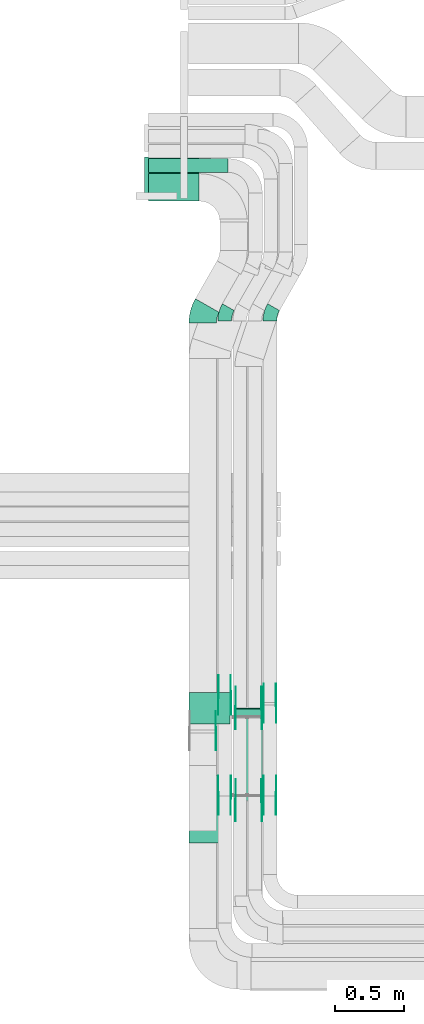
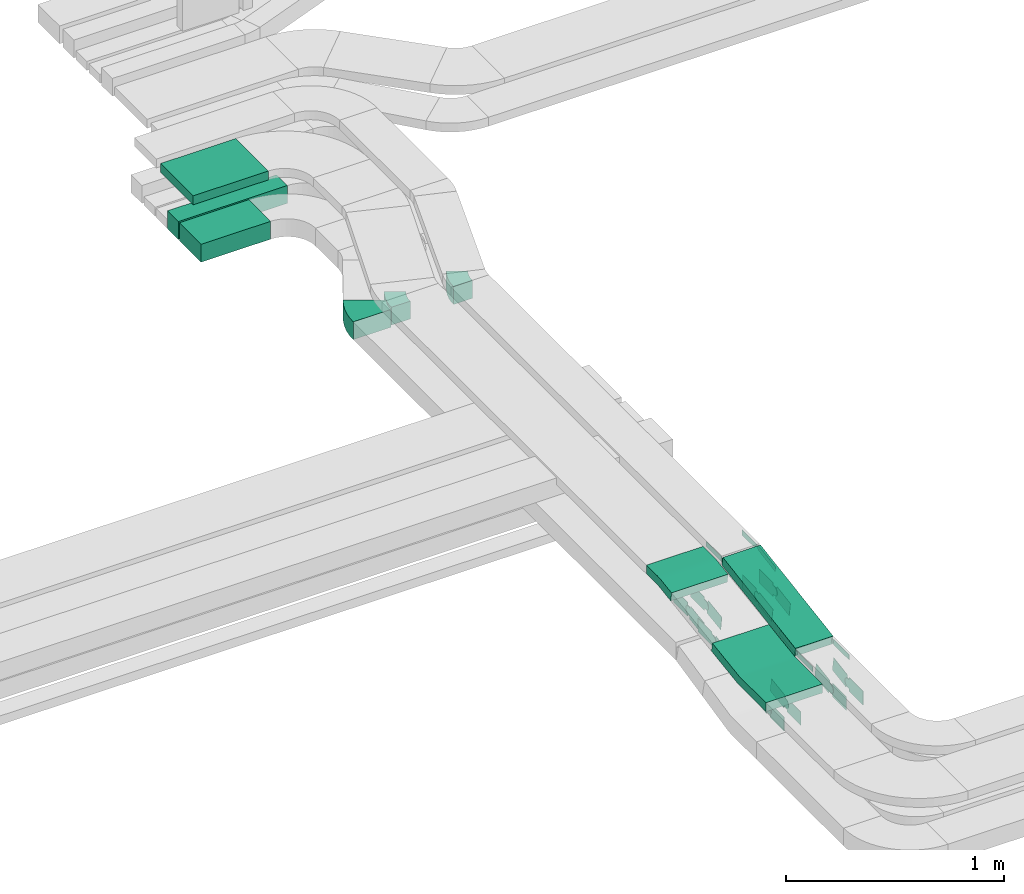
# One storey, part 5 of 31: 31 flow fittings, 4 flow segments.
"""IFC2X3 building model written with IfcOpenShell, lengths in millimetres."""

import ifcopenshell
import ifcopenshell.guid

model = None  # the IFC model being written
_history = None  # IfcOwnerHistory: only IFC2X3 demands one
_inside = {}  # id of a spatial element -> (the spatial element, [elements in it])
_under = {}  # id of a project, library or spatial element -> (it, [spatial elements below it])
_declared = {}  # id of a project -> (the project, [libraries it declares])
_typed = {}  # id of a type object -> (the type object, [elements of that type])
_made_of = {}  # id of a material, layer set ... -> (it, [elements and type objects made of it])


def new_model(schema):
    """Start an empty IFC model of exactly this schema.

    Asked for "IFC4X3", IfcOpenShell would pick the latest addendum, in which some entities
    have other attributes; the version numbers below select the first issue.
    IFC2X3 requires an IfcOwnerHistory on every rooted entity: one is made here for all.
    """
    global model, _history
    if schema == "IFC4X3":
        model = ifcopenshell.file(schema_version=(4, 3, 0, 0))
    else:
        model = ifcopenshell.file(schema=schema)
    _inside.clear()
    _under.clear()
    _declared.clear()
    _typed.clear()
    _made_of.clear()
    _history = None
    if model.schema == "IFC2X3":
        org = make("IfcOrganization", Name="unknown")
        user = make(
            "IfcPersonAndOrganization",
            ThePerson=make("IfcPerson", FamilyName="unknown"),
            TheOrganization=org,
        )
        app = make(
            "IfcApplication",
            ApplicationDeveloper=org,
            Version="unknown",
            ApplicationFullName="unknown",
            ApplicationIdentifier="unknown",
        )
        _history = make(
            "IfcOwnerHistory",
            OwningUser=user,
            OwningApplication=app,
            ChangeAction="ADDED",
            CreationDate=0,
        )
    return model


def make(cls, **values):
    """One entity of the class cls with the attributes given. An attribute that is None is left unset."""
    return model.create_entity(
        cls, **{name: value for name, value in values.items() if value is not None}
    )


def entity(cls, *values):
    """Any entity or typed value of the class cls, its attributes in the order of the schema. None: left unset."""
    e = model.create_entity(cls)
    for i, value in enumerate(values):
        if value is not None:
            e[i] = value
    return e


def rooted(cls, **values):
    """An entity with a GlobalId (a new one), such as an element, a storey or a relation."""
    return make(cls, GlobalId=ifcopenshell.guid.new(), OwnerHistory=_history, **values)


def si_unit(unit_type, name, prefix=None):
    """IfcSIUnit, for example si_unit("LENGTHUNIT", "METRE", prefix="MILLI")."""
    return make("IfcSIUnit", UnitType=unit_type, Prefix=prefix, Name=name)


def converted_unit(unit_type, name, factor, base, dimensions=None, offset=None):
    """IfcConversionBasedUnit, such as the inch: factor (a typed value) times the base unit."""
    return make(
        "IfcConversionBasedUnit"
        if offset is None
        else "IfcConversionBasedUnitWithOffset",
        ConversionOffset=offset,
        Dimensions=None
        if dimensions is None
        else entity("IfcDimensionalExponents", *dimensions),
        UnitType=unit_type,
        Name=name,
        ConversionFactor=make(
            "IfcMeasureWithUnit", ValueComponent=factor, UnitComponent=base
        ),
    )


def derived_unit(unit_type, elements):
    """IfcDerivedUnit: a product of units, each with its exponent."""
    return make(
        "IfcDerivedUnit",
        Elements=[
            make("IfcDerivedUnitElement", Unit=unit, Exponent=power)
            for unit, power in elements
        ],
        UnitType=unit_type,
    )


def assignment(units):
    """IfcUnitAssignment: the units of a project."""
    return None if units is None else make("IfcUnitAssignment", Units=units)


def point(xyz):
    """IfcCartesianPoint."""
    return None if xyz is None else make("IfcCartesianPoint", Coordinates=xyz)


def direction(xyz):
    """IfcDirection."""
    return None if xyz is None else make("IfcDirection", DirectionRatios=xyz)


def frame(location, z_axis=None, x_axis=None):
    """IfcAxis2Placement3D, a coordinate frame: its origin and axes. An axis left out is left unset."""
    return make(
        "IfcAxis2Placement3D",
        Location=point(location),
        Axis=direction(z_axis),
        RefDirection=direction(x_axis),
    )


def frame_2d(location, x_axis=None):
    """IfcAxis2Placement2D, a coordinate frame in the plane: its origin and x axis."""
    return make(
        "IfcAxis2Placement2D", Location=point(location), RefDirection=direction(x_axis)
    )


def origin():
    """The frame at (0, 0, 0) with its axes left unset."""
    return frame((0.0, 0.0, 0.0))


def place(relative_to, where):
    """IfcLocalPlacement: puts the frame where relative to a parent placement (None: the world)."""
    return make(
        "IfcLocalPlacement", PlacementRelTo=relative_to, RelativePlacement=where
    )


def context(
    kind, dimensions, precision=None, world=None, true_north=None, identifier=None
):
    """IfcGeometricRepresentationContext, for example the 3D "Model" context."""
    return make(
        "IfcGeometricRepresentationContext",
        ContextIdentifier=identifier,
        ContextType=kind,
        CoordinateSpaceDimension=dimensions,
        Precision=precision,
        WorldCoordinateSystem=world,
        TrueNorth=true_north,
    )


def subcontext(parent, identifier, kind, view, scale=None):
    """IfcGeometricRepresentationSubContext, for example "Body" below "Model"."""
    return make(
        "IfcGeometricRepresentationSubContext",
        ContextIdentifier=identifier,
        ContextType=kind,
        ParentContext=parent,
        TargetScale=scale,
        TargetView=view,
    )


def project(units=None, contexts=None):
    """IfcProject with its units and contexts."""
    return rooted(
        "IfcProject",
        Name="project",
        RepresentationContexts=contexts,
        UnitsInContext=assignment(units),
    )


def spatial(cls, under=None, at=None, **own):
    """A site, building, storey or space (cls), placed at a placement, below another one or the project."""
    s = rooted(cls, ObjectPlacement=at, **own)
    if under is not None:
        _under.setdefault(under.id(), (under, []))[1].append(s)
    return s


def polyline(points):
    """IfcPolyline through the points."""
    return make("IfcPolyline", Points=[point(p) for p in points])


def circle_curve(where, radius):
    """IfcCircle in the frame where."""
    return make("IfcCircle", Position=where, Radius=radius)


def parameter(value):
    """IfcParameterValue: where a trimmed curve begins or ends, as a parameter of its basis curve."""
    return model.create_entity("IfcParameterValue", value)


def trimmed(basis, trim1, trim2, sense, master):
    """IfcTrimmedCurve: the piece of a basis curve between two trims."""
    return make(
        "IfcTrimmedCurve",
        BasisCurve=basis,
        Trim1=trim1,
        Trim2=trim2,
        SenseAgreement=sense,
        MasterRepresentation=master,
    )


def segment(curve, same_sense, transition):
    """IfcCompositeCurveSegment."""
    return make(
        "IfcCompositeCurveSegment",
        Transition=transition,
        SameSense=same_sense,
        ParentCurve=curve,
    )


def composite_curve(segments, self_intersect=None):
    """IfcCompositeCurve: segments joined end to end."""
    return make("IfcCompositeCurve", Segments=segments, SelfIntersect=self_intersect)


def profile(cls, at=None, kind="AREA", **sizes):
    """A parametric profile (cls). Its sizes go by their IFC names, for example OverallWidth=200.0."""
    return make(cls, ProfileType=kind, Position=at, **sizes)


def rectangle(**sizes):
    """IfcRectangleProfileDef."""
    return profile("IfcRectangleProfileDef", **sizes)


def outline(outer, holes=None, kind="AREA"):
    """IfcArbitraryClosedProfileDef: a profile drawn as a closed curve; with holes, ...WithVoids."""
    if holes is None:
        return make("IfcArbitraryClosedProfileDef", ProfileType=kind, OuterCurve=outer)
    return make(
        "IfcArbitraryProfileDefWithVoids",
        ProfileType=kind,
        OuterCurve=outer,
        InnerCurves=holes,
    )


def extrude(swept, where, along, depth):
    """IfcExtrudedAreaSolid: the profile swept, set in the frame where, extruded along a direction by depth."""
    return make(
        "IfcExtrudedAreaSolid",
        SweptArea=swept,
        Position=where,
        ExtrudedDirection=direction(along),
        Depth=depth,
    )


def shape(context_of_items, identifier, shape_type, items):
    """IfcShapeRepresentation: the items that make up one representation, for example the "Body"."""
    return make(
        "IfcShapeRepresentation",
        ContextOfItems=context_of_items,
        RepresentationIdentifier=identifier,
        RepresentationType=shape_type,
        Items=items,
    )


def source(mapping_origin, context_of_items, identifier, shape_type, items):
    """IfcRepresentationMap: a shape defined once, which mapped items show again and again."""
    return make(
        "IfcRepresentationMap",
        MappingOrigin=mapping_origin,
        MappedRepresentation=shape(context_of_items, identifier, shape_type, items),
    )


def transform(
    local_origin,
    x_axis=None,
    y_axis=None,
    z_axis=None,
    scale=None,
    scale2=None,
    scale3=None,
    uniform=True,
):
    """IfcCartesianTransformationOperator3D, or its non-uniform kind. x_axis, y_axis, z_axis: its Axis1, 2, 3."""
    if uniform:
        return make(
            "IfcCartesianTransformationOperator3D",
            Axis1=direction(x_axis),
            Axis2=direction(y_axis),
            LocalOrigin=point(local_origin),
            Scale=scale,
            Axis3=direction(z_axis),
        )
    return make(
        "IfcCartesianTransformationOperator3DnonUniform",
        Axis1=direction(x_axis),
        Axis2=direction(y_axis),
        LocalOrigin=point(local_origin),
        Scale=scale,
        Axis3=direction(z_axis),
        Scale2=scale2,
        Scale3=scale3,
    )


def mapped(mapping_source, mapping_target):
    """IfcMappedItem: shows the shape of a source again, moved by a transform."""
    return make(
        "IfcMappedItem", MappingSource=mapping_source, MappingTarget=mapping_target
    )


def material(Name=None, Category=None):
    """IfcMaterial."""
    return make("IfcMaterial", Name=Name, Category=Category)


def made_of(thing, what):
    """Note that an element or type object is made of a material, layer set ...; save() writes the relation."""
    if what is not None:
        _made_of.setdefault(what.id(), (what, []))[1].append(thing)
    return thing


def type_object(cls, material=None, **own):
    """A type object (cls), such as IfcWallType, which elements share."""
    return made_of(rooted(cls, **own), material)


def type_shapes(of_type, sources):
    """Give a type object the sources (RepresentationMaps) that its elements show as mapped items."""
    of_type.RepresentationMaps = sources


def element(
    cls,
    number,
    at=None,
    inside=None,
    cuts=None,
    type_object=None,
    material=None,
    context=None,
    identifier="Body",
    shape_type=None,
    held_by="IfcProductDefinitionShape",
    body=None,
    shapes=None,
    **own,
):
    """One element of the class cls, such as IfcWall. Its Tag is "e" and its number.

    at: its placement. inside: the storey or other place that contains it. cuts: it is an
    opening in that element (IfcRelVoidsElement). A single representation is given by context,
    identifier, shape_type and body (its items); several are given by shapes. held_by: the class
    of the entity that holds the representations. save() writes the other relations.
    """
    e = rooted(cls, Tag="e%d" % number, ObjectPlacement=at, **own)
    if body is not None:
        shapes = [shape(context, identifier, shape_type, body)]
    if shapes is not None:
        e.Representation = make(held_by, Representations=shapes)
    if inside is not None:
        _inside.setdefault(inside.id(), (inside, []))[1].append(e)
    if cuts is not None:
        rooted(
            "IfcRelVoidsElement", RelatingBuildingElement=cuts, RelatedOpeningElement=e
        )
    if type_object is not None:
        _typed.setdefault(type_object.id(), (type_object, []))[1].append(e)
    return made_of(e, material)


def aggregate(whole, parts):
    """IfcRelAggregates: a whole, such as a stair, and the parts it consists of."""
    return rooted("IfcRelAggregates", RelatingObject=whole, RelatedObjects=parts)


def save(model, path):
    """Write the relations noted so far, then the file.

    IfcRelAggregates (storeys below a building ...), IfcRelContainedInSpatialStructure (elements
    in a storey), IfcRelDefinesByType, IfcRelAssociatesMaterial and IfcRelDeclares: one each for
    every whole, place, type object, material and project.
    """
    for whole, parts in _under.values():
        aggregate(whole, parts)
    for where, things in _inside.values():
        rooted(
            "IfcRelContainedInSpatialStructure",
            RelatedElements=things,
            RelatingStructure=where,
        )
    for kind, things in _typed.values():
        rooted("IfcRelDefinesByType", RelatedObjects=things, RelatingType=kind)
    for what, things in _made_of.values():
        rooted("IfcRelAssociatesMaterial", RelatedObjects=things, RelatingMaterial=what)
    for by, libraries in _declared.values():
        rooted("IfcRelDeclares", RelatingContext=by, RelatedDefinitions=libraries)
    model.write(path)


model = new_model("IFC2X3")

# Units and contexts
model_context = context("Model", 3, precision=0.01, world=origin(), true_north=direction((6.12303176911189e-17, 1.0)))
body_context = subcontext(model_context, "Body", "Model", "MODEL_VIEW")
ifc_project = project(units=[si_unit("LENGTHUNIT", "METRE", prefix="MILLI"), si_unit("AREAUNIT", "SQUARE_METRE"), si_unit("VOLUMEUNIT", "CUBIC_METRE"), converted_unit("PLANEANGLEUNIT", "DEGREE", entity("IfcRatioMeasure", 0.0174532925199433), si_unit("PLANEANGLEUNIT", "RADIAN"), dimensions=[0, 0, 0, 0, 0, 0, 0]), si_unit("MASSUNIT", "GRAM", prefix="KILO"), derived_unit("MASSDENSITYUNIT", [(si_unit("MASSUNIT", "GRAM", prefix="KILO"), 1), (si_unit("LENGTHUNIT", "METRE"), -3)]), derived_unit("MOMENTOFINERTIAUNIT", [(si_unit("LENGTHUNIT", "METRE"), 4)]), si_unit("TIMEUNIT", "SECOND"), si_unit("FREQUENCYUNIT", "HERTZ"), si_unit("THERMODYNAMICTEMPERATUREUNIT", "DEGREE_CELSIUS"), derived_unit("THERMALTRANSMITTANCEUNIT", [(si_unit("MASSUNIT", "GRAM", prefix="KILO"), 1), (si_unit("THERMODYNAMICTEMPERATUREUNIT", "KELVIN"), -1), (si_unit("TIMEUNIT", "SECOND"), -3)]), derived_unit("VOLUMETRICFLOWRATEUNIT", [(si_unit("LENGTHUNIT", "METRE"), 3), (si_unit("TIMEUNIT", "SECOND"), -1)]), derived_unit("MASSFLOWRATEUNIT", [(si_unit("MASSUNIT", "GRAM", prefix="KILO"), 1), (si_unit("TIMEUNIT", "SECOND"), -1)]), derived_unit("ROTATIONALFREQUENCYUNIT", [(si_unit("TIMEUNIT", "SECOND"), -1)]), si_unit("ELECTRICCURRENTUNIT", "AMPERE"), si_unit("ELECTRICVOLTAGEUNIT", "VOLT"), si_unit("POWERUNIT", "WATT"), si_unit("FORCEUNIT", "NEWTON", prefix="KILO"), si_unit("ILLUMINANCEUNIT", "LUX"), si_unit("LUMINOUSFLUXUNIT", "LUMEN"), si_unit("LUMINOUSINTENSITYUNIT", "CANDELA"), derived_unit("USERDEFINED", [(si_unit("MASSUNIT", "GRAM", prefix="KILO"), -1), (si_unit("LENGTHUNIT", "METRE"), -2), (si_unit("TIMEUNIT", "SECOND"), 3), (si_unit("LUMINOUSFLUXUNIT", "LUMEN"), 1)]), derived_unit("LINEARVELOCITYUNIT", [(si_unit("LENGTHUNIT", "METRE"), 1), (si_unit("TIMEUNIT", "SECOND"), -1)]), si_unit("PRESSUREUNIT", "PASCAL"), derived_unit("USERDEFINED", [(si_unit("LENGTHUNIT", "METRE"), -2), (si_unit("MASSUNIT", "GRAM", prefix="KILO"), 1), (si_unit("TIMEUNIT", "SECOND"), -2)]), derived_unit("LINEARFORCEUNIT", [(si_unit("MASSUNIT", "GRAM", prefix="KILO"), 1), (si_unit("LENGTHUNIT", "METRE"), 1), (si_unit("TIMEUNIT", "SECOND"), -2), (si_unit("LENGTHUNIT", "METRE"), -1)]), derived_unit("PLANARFORCEUNIT", [(si_unit("MASSUNIT", "GRAM", prefix="KILO"), 1), (si_unit("LENGTHUNIT", "METRE"), 1), (si_unit("TIMEUNIT", "SECOND"), -2), (si_unit("LENGTHUNIT", "METRE"), -2)])], contexts=[model_context])

# Site, building, storey
site_placement = place(None, frame((0.0, -0.00077364408347762, 0.0)))
site = spatial("IfcSite", under=ifc_project, at=site_placement, CompositionType="ELEMENT")
building_placement = place(site_placement, origin())
building = spatial("IfcBuilding", under=site, at=building_placement, CompositionType="ELEMENT")
storey_placement = place(building_placement, frame((0.0, 0.0, 15900.0)))
storey = spatial("IfcBuildingStorey", under=building, at=storey_placement, CompositionType="ELEMENT", Elevation=15900.0)

# Flow segments
cable_carrier_segment_type = type_object("IfcCableCarrierSegmentType", PredefinedType="CABLETRAYSEGMENT")
flow_segment_1_placement = place(storey_placement, frame((16238.5446118447, 13970.0, 2607.25805153974)))
element("IfcFlowSegment", 1, at=flow_segment_1_placement, inside=storey, type_object=cable_carrier_segment_type, context=body_context, shape_type="SweptSolid", body=[
    extrude(rectangle(XDim=369.000000000007, YDim=200.000000000002, at=frame_2d((0.0, 2.16715534406831e-12), x_axis=(1.0, 0.0))), frame((184.500000000004, 100.0, 0.0), z_axis=(0.0, 0.0, 1.0), x_axis=(-1.0, 0.0, 0.0)), (0.0, 0.0, 1.0), 99.9999999999989),
])
flow_segment_2_placement = place(storey_placement, frame((16238.5446118447, 14180.0, 2607.25805153974)))
element("IfcFlowSegment", 2, at=flow_segment_2_placement, inside=storey, type_object=cable_carrier_segment_type, context=body_context, shape_type="SweptSolid", body=[
    extrude(rectangle(XDim=579.000000000005, YDim=99.9999999999989, at=frame_2d((-1.10844666778576e-12, -1.08357767203415e-12), x_axis=(1.0, 0.0))), frame((289.500000000003, 50.0, 0.0), z_axis=(0.0, 0.0, 1.0), x_axis=(-1.0, 0.0, 0.0)), (0.0, 0.0, 1.0), 99.9999999999989),
])
flow_segment_3_placement = place(storey_placement, frame((16208.5446118446, 13990.5260416215, 2927.25805153973)))
element("IfcFlowSegment", 3, at=flow_segment_3_placement, inside=storey, type_object=cable_carrier_segment_type, context=body_context, shape_type="SweptSolid", body=[
    extrude(rectangle(XDim=399.000000000007, YDim=300.000000000001, at=frame_2d((-1.08002495835535e-12, 0.0), x_axis=(1.0, 0.0))), frame((199.500000000002, 150.0, 0.0), z_axis=(0.0, 0.0, 1.0), x_axis=(-1.0, 0.0, 0.0)), (0.0, 0.0, 1.0), 50.0000000000038),
])
flow_segment_4_placement = place(storey_placement, frame((16868.5, 9599.04701910755, 2820.82802537747)))
element("IfcFlowSegment", 4, at=flow_segment_4_placement, inside=storey, type_object=cable_carrier_segment_type, context=body_context, shape_type="SweptSolid", body=[
    extrude(rectangle(XDim=50.0000000000019, YDim=675.974661481006, at=frame_2d((1.4495071809506e-12, -1.32516220219259e-12), x_axis=(0.0, 1.0))), frame((0.0, 337.716767227312, 77.8010003923927), z_axis=(1.0, 0.0, 0.0), x_axis=(0.0, -0.987576211285318, -0.157140786886588)), (0.0, 0.0, 1.0), 199.999999999998),
])

# Flow fittings
ifc_material_1 = material(Name="G")
cable_carrier_fitting_type_1 = type_object("IfcCableCarrierFittingType", PredefinedType="NOTDEFINED", material=ifc_material_1)
shared_shape_1 = source(origin(), body_context, "Body", "SweptSolid", [
    extrude(outline(composite_curve([segment(trimmed(circle_curve(frame_2d((-44.5901162790698, 0.0), x_axis=(1.0, 0.0)), 12.5), [parameter(90.0000000000007)], [parameter(270.0)], True, "PARAMETER"), True, "CONTINUOUS"), segment(polyline([(-44.5901162790697, -12.5), (-33.0901162790698, -12.5)]), True, "CONTINUOUS"), segment(polyline([(-33.0901162790698, -12.5), (-31.2296511627907, -14.5)]), True, "CONTINUOUS"), segment(polyline([(-31.2296511627907, -14.5), (108.90988372093, -14.5)]), True, "CONTINUOUS"), segment(polyline([(108.90988372093, -14.5), (108.90988372093, 14.5)]), True, "CONTINUOUS"), segment(polyline([(108.90988372093, 14.5), (-31.2296511627907, 14.5)]), True, "CONTINUOUS"), segment(polyline([(-31.2296511627907, 14.5), (-33.0901162790698, 12.5)]), True, "CONTINUOUS"), segment(polyline([(-33.0901162790698, 12.5), (-44.5901162790699, 12.5)]), True, "CONTINUOUS")], self_intersect=False)), frame((44.5901162790698, 0.0, 0.0), z_axis=(0.0, 0.0, -1.0), x_axis=(1.0, 0.0, 0.0)), (0.0, 0.0, -1.0), 2.0),
])
type_shapes(cable_carrier_fitting_type_1, [shared_shape_1])
for number, where, z_axis, x_axis in (
    (5, (17063.9600000101, 10273.8039089795, 2952.25805153975), (1.0, 0.0, 0.0), (0.0, -0.987576211285316, -0.157140786886606)),
    (6, (16873.0399999898, 9599.72366369022, 2845.0), (-1.0, 0.0, 0.0), (0.0, -1.0, 0.0)),
):
    element("IfcFlowFitting", number, at=place(storey_placement, frame(where, z_axis=z_axis, x_axis=x_axis)), inside=storey, type_object=cable_carrier_fitting_type_1, material=ifc_material_1, context=body_context, shape_type="MappedRepresentation", body=[
        mapped(shared_shape_1, transform((0.0, 0.0, 0.0), scale=1.0)),
    ])
cable_carrier_fitting_type_2 = type_object("IfcCableCarrierFittingType", PredefinedType="NOTDEFINED", material=ifc_material_1)
shared_shape_2 = source(origin(), body_context, "Body", "SweptSolid", [
    extrude(outline(composite_curve([segment(trimmed(circle_curve(frame_2d((-44.5901162790697, 0.0), x_axis=(1.0, 0.0)), 12.5), [parameter(90.0000000000007)], [parameter(270.0)], True, "PARAMETER"), True, "CONTINUOUS"), segment(polyline([(-44.5901162790697, -12.5), (-33.0901162790697, -12.5)]), True, "CONTINUOUS"), segment(polyline([(-33.0901162790697, -12.5), (-31.2296511627907, -14.5)]), True, "CONTINUOUS"), segment(polyline([(-31.2296511627907, -14.5), (108.90988372093, -14.5)]), True, "CONTINUOUS"), segment(polyline([(108.90988372093, -14.5), (108.90988372093, 14.5)]), True, "CONTINUOUS"), segment(polyline([(108.90988372093, 14.5), (-31.2296511627907, 14.5)]), True, "CONTINUOUS"), segment(polyline([(-31.2296511627907, 14.5), (-33.0901162790698, 12.5)]), True, "CONTINUOUS"), segment(polyline([(-33.0901162790698, 12.5), (-44.5901162790699, 12.5)]), True, "CONTINUOUS")], self_intersect=False)), frame((44.5901162790697, 0.0, 0.0)), (0.0, 0.0, 1.0), 2.0),
])
type_shapes(cable_carrier_fitting_type_2, [shared_shape_2])
for number, where, z_axis, x_axis in (
    (7, (16873.0399999898, 10273.8039089795, 2952.25805153975), (-1.0, 0.0, 0.0), (0.0, -0.987576211285316, -0.157140786886606)),
    (8, (17063.9600000101, 9599.72366369022, 2845.0), (1.0, 0.0, 0.0), (0.0, -1.0, 0.0)),
):
    element("IfcFlowFitting", number, at=place(storey_placement, frame(where, z_axis=z_axis, x_axis=x_axis)), inside=storey, type_object=cable_carrier_fitting_type_2, material=ifc_material_1, context=body_context, shape_type="MappedRepresentation", body=[
        mapped(shared_shape_2, transform((0.0, 0.0, 0.0), scale=1.0)),
    ])
cable_carrier_fitting_type_3 = type_object("IfcCableCarrierFittingType", PredefinedType="NOTDEFINED", material=ifc_material_1)
shared_shape_3 = source(origin(), body_context, "Body", "SweptSolid", [
    extrude(outline(composite_curve([segment(trimmed(circle_curve(frame_2d((-44.5901162790698, 0.0), x_axis=(1.0, 0.0)), 12.5), [parameter(90.0000000000007)], [parameter(270.0)], True, "PARAMETER"), True, "CONTINUOUS"), segment(polyline([(-44.5901162790697, -12.5), (-33.0901162790698, -12.5)]), True, "CONTINUOUS"), segment(polyline([(-33.0901162790698, -12.5), (-31.2296511627907, -14.5)]), True, "CONTINUOUS"), segment(polyline([(-31.2296511627907, -14.5), (108.90988372093, -14.5)]), True, "CONTINUOUS"), segment(polyline([(108.90988372093, -14.5), (108.90988372093, 14.5)]), True, "CONTINUOUS"), segment(polyline([(108.90988372093, 14.5), (-31.2296511627907, 14.5)]), True, "CONTINUOUS"), segment(polyline([(-31.2296511627907, 14.5), (-33.0901162790698, 12.5)]), True, "CONTINUOUS"), segment(polyline([(-33.0901162790698, 12.5), (-44.5901162790699, 12.5)]), True, "CONTINUOUS")], self_intersect=False)), frame((44.5901162790698, 0.0, 0.0), z_axis=(0.0, 0.0, -1.0), x_axis=(1.0, 0.0, 0.0)), (0.0, 0.0, -1.0), 2.0),
])
type_shapes(cable_carrier_fitting_type_3, [shared_shape_3])
for number, where, z_axis, x_axis in (
    (9, (16875.0399999898, 10273.8039089795, 2952.25805153975), (-1.0, 0.0, 0.0), (0.0, 1.0, 0.0)),
    (10, (17061.9600000101, 9599.7236636902, 2845.0), (1.0, 0.0, 0.0), (0.0, 0.987576211285319, 0.157140786886585)),
):
    element("IfcFlowFitting", number, at=place(storey_placement, frame(where, z_axis=z_axis, x_axis=x_axis)), inside=storey, type_object=cable_carrier_fitting_type_3, material=ifc_material_1, context=body_context, shape_type="MappedRepresentation", body=[
        mapped(shared_shape_3, transform((0.0, 0.0, 0.0), scale=1.0)),
    ])
cable_carrier_fitting_type_4 = type_object("IfcCableCarrierFittingType", PredefinedType="NOTDEFINED", material=ifc_material_1)
shared_shape_4 = source(origin(), body_context, "Body", "SweptSolid", [
    extrude(outline(composite_curve([segment(trimmed(circle_curve(frame_2d((-44.5901162790697, 0.0), x_axis=(1.0, 0.0)), 12.5), [parameter(90.0000000000007)], [parameter(270.0)], True, "PARAMETER"), True, "CONTINUOUS"), segment(polyline([(-44.5901162790697, -12.5), (-33.0901162790697, -12.5)]), True, "CONTINUOUS"), segment(polyline([(-33.0901162790697, -12.5), (-31.2296511627907, -14.5)]), True, "CONTINUOUS"), segment(polyline([(-31.2296511627907, -14.5), (108.90988372093, -14.5)]), True, "CONTINUOUS"), segment(polyline([(108.90988372093, -14.5), (108.90988372093, 14.5)]), True, "CONTINUOUS"), segment(polyline([(108.90988372093, 14.5), (-31.2296511627907, 14.5)]), True, "CONTINUOUS"), segment(polyline([(-31.2296511627907, 14.5), (-33.0901162790698, 12.5)]), True, "CONTINUOUS"), segment(polyline([(-33.0901162790698, 12.5), (-44.5901162790699, 12.5)]), True, "CONTINUOUS")], self_intersect=False)), frame((44.5901162790697, 0.0, 0.0)), (0.0, 0.0, 1.0), 2.0),
])
type_shapes(cable_carrier_fitting_type_4, [shared_shape_4])
for number, where, z_axis, x_axis in (
    (11, (17061.9600000101, 10273.8039089795, 2952.25805153975), (1.0, 0.0, 0.0), (0.0, 1.0, 0.0)),
    (12, (16875.0399999898, 9599.7236636902, 2845.0), (-1.0, 0.0, 0.0), (0.0, 0.987576211285319, 0.157140786886585)),
):
    element("IfcFlowFitting", number, at=place(storey_placement, frame(where, z_axis=z_axis, x_axis=x_axis)), inside=storey, type_object=cable_carrier_fitting_type_4, material=ifc_material_1, context=body_context, shape_type="MappedRepresentation", body=[
        mapped(shared_shape_4, transform((0.0, 0.0, 0.0), scale=1.0)),
    ])
cable_carrier_fitting_type_5 = type_object("IfcCableCarrierFittingType", PredefinedType="NOTDEFINED", material=ifc_material_1)
shared_shape_5 = source(origin(), body_context, "Body", "SweptSolid", [
    extrude(outline(composite_curve([segment(trimmed(circle_curve(frame_2d((-41.4651162790697, 0.0), x_axis=(1.0, 0.0)), 25.0), [parameter(90.0000000000007)], [parameter(270.0)], True, "PARAMETER"), True, "CONTINUOUS"), segment(polyline([(-41.4651162790697, -25.0), (-29.9651162790697, -25.0)]), True, "CONTINUOUS"), segment(polyline([(-29.9651162790697, -25.0), (-28.1046511627907, -38.5)]), True, "CONTINUOUS"), segment(polyline([(-28.1046511627907, -38.5), (99.5348837209303, -38.5)]), True, "CONTINUOUS"), segment(polyline([(99.5348837209303, -38.5), (99.5348837209303, 38.5)]), True, "CONTINUOUS"), segment(polyline([(99.5348837209303, 38.5), (-28.1046511627907, 38.5)]), True, "CONTINUOUS"), segment(polyline([(-28.1046511627907, 38.5), (-29.9651162790697, 25.0)]), True, "CONTINUOUS"), segment(polyline([(-29.9651162790697, 25.0), (-41.46511627907, 25.0)]), True, "CONTINUOUS")], self_intersect=False)), frame((41.4651162790697, 0.0, 0.0), z_axis=(0.0, 0.0, -1.0), x_axis=(1.0, 0.0, 0.0)), (0.0, 0.0, -1.0), 2.0),
])
type_shapes(cable_carrier_fitting_type_5, [shared_shape_5])
for number, where, z_axis, x_axis in (
    (13, (16838.9600000101, 10369.8113481977, 2657.25805153976), (1.0, 0.0, 0.0), (0.0, -0.989493546804656, -0.144577041164712)),
    (14, (17168.9600000101, 10309.8113481977, 2657.25805153977), (1.0, 0.0, 0.0), (0.0, -0.987576211285325, -0.15714078688655)),
    (15, (16838.9600000101, 9635.73110290811, 2550.0), (1.0, 0.0, 0.0), (0.0, 0.989493546804656, 0.144577041164712)),
    (16, (17168.9600000101, 9635.73110290811, 2550.0), (1.0, 0.0, 0.0), (0.0, 0.987576211285325, 0.15714078688655)),
    (17, (16728.9600000101, 10109.8113481977, 2657.25805153976), (1.0, 0.0, 0.0), (0.0, -0.976627229070768, -0.214940120586069)),
):
    element("IfcFlowFitting", number, at=place(storey_placement, frame(where, z_axis=z_axis, x_axis=x_axis)), inside=storey, type_object=cable_carrier_fitting_type_5, material=ifc_material_1, context=body_context, shape_type="MappedRepresentation", body=[
        mapped(shared_shape_5, transform((0.0, 0.0, 0.0), scale=1.0)),
    ])
cable_carrier_fitting_type_6 = type_object("IfcCableCarrierFittingType", PredefinedType="NOTDEFINED", material=ifc_material_1)
shared_shape_6 = source(origin(), body_context, "Body", "SweptSolid", [
    extrude(outline(composite_curve([segment(trimmed(circle_curve(frame_2d((-41.4651162790697, 0.0), x_axis=(1.0, 0.0)), 25.0), [parameter(90.0000000000007)], [parameter(270.0)], True, "PARAMETER"), True, "CONTINUOUS"), segment(polyline([(-41.4651162790697, -25.0), (-29.9651162790697, -25.0)]), True, "CONTINUOUS"), segment(polyline([(-29.9651162790697, -25.0), (-28.1046511627907, -38.5)]), True, "CONTINUOUS"), segment(polyline([(-28.1046511627907, -38.5), (99.5348837209303, -38.5)]), True, "CONTINUOUS"), segment(polyline([(99.5348837209303, -38.5), (99.5348837209303, 38.5)]), True, "CONTINUOUS"), segment(polyline([(99.5348837209303, 38.5), (-28.1046511627907, 38.5)]), True, "CONTINUOUS"), segment(polyline([(-28.1046511627907, 38.5), (-29.9651162790697, 25.0)]), True, "CONTINUOUS"), segment(polyline([(-29.9651162790697, 25.0), (-41.46511627907, 25.0)]), True, "CONTINUOUS")], self_intersect=False)), frame((41.4651162790697, 0.0, 0.0)), (0.0, 0.0, 1.0), 2.0),
])
type_shapes(cable_carrier_fitting_type_6, [shared_shape_6])
for number, where, z_axis, x_axis in (
    (18, (16748.0399999898, 10369.8113481977, 2657.25805153977), (-1.0, 0.0, 0.0), (0.0, -0.989493546804656, -0.144577041164712)),
    (19, (17078.0399999898, 10309.8113481977, 2657.25805153977), (-1.0, 0.0, 0.0), (0.0, -0.987576211285325, -0.15714078688655)),
    (20, (16748.0399999898, 9635.7311029081, 2550.0), (-1.0, 0.0, 0.0), (0.0, 0.989493546804656, 0.144577041164712)),
    (21, (17078.0399999898, 9635.73110290811, 2550.0), (-1.0, 0.0, 0.0), (0.0, 0.987576211285325, 0.15714078688655)),
):
    element("IfcFlowFitting", number, at=place(storey_placement, frame(where, z_axis=z_axis, x_axis=x_axis)), inside=storey, type_object=cable_carrier_fitting_type_6, material=ifc_material_1, context=body_context, shape_type="MappedRepresentation", body=[
        mapped(shared_shape_6, transform((0.0, 0.0, 0.0), scale=1.0)),
    ])
cable_carrier_fitting_type_7 = type_object("IfcCableCarrierFittingType", PredefinedType="NOTDEFINED", material=ifc_material_1)
shared_shape_7 = source(origin(), body_context, "Body", "SweptSolid", [
    extrude(outline(composite_curve([segment(trimmed(circle_curve(frame_2d((-41.4651162790697, 0.0), x_axis=(1.0, 0.0)), 25.0), [parameter(90.0000000000007)], [parameter(270.0)], True, "PARAMETER"), True, "CONTINUOUS"), segment(polyline([(-41.4651162790697, -25.0), (-29.9651162790697, -25.0)]), True, "CONTINUOUS"), segment(polyline([(-29.9651162790697, -25.0), (-28.1046511627907, -38.5)]), True, "CONTINUOUS"), segment(polyline([(-28.1046511627907, -38.5), (99.5348837209303, -38.5)]), True, "CONTINUOUS"), segment(polyline([(99.5348837209303, -38.5), (99.5348837209303, 38.5)]), True, "CONTINUOUS"), segment(polyline([(99.5348837209303, 38.5), (-28.1046511627907, 38.5)]), True, "CONTINUOUS"), segment(polyline([(-28.1046511627907, 38.5), (-29.9651162790697, 25.0)]), True, "CONTINUOUS"), segment(polyline([(-29.9651162790697, 25.0), (-41.46511627907, 25.0)]), True, "CONTINUOUS")], self_intersect=False)), frame((41.4651162790697, 0.0, 0.0), z_axis=(0.0, 0.0, -1.0), x_axis=(1.0, 0.0, 0.0)), (0.0, 0.0, -1.0), 2.0),
])
type_shapes(cable_carrier_fitting_type_7, [shared_shape_7])
for number, where, z_axis, x_axis in (
    (22, (16750.0399999898, 10369.8113481977, 2657.25805153976), (-1.0, 0.0, 0.0), (0.0, 1.0, 0.0)),
    (23, (17080.0399999898, 10309.8113481977, 2657.25805153976), (-1.0, 0.0, 0.0), (0.0, 1.0, 0.0)),
    (24, (16750.0399999898, 9635.73110290813, 2550.0), (-1.0, 0.0, 0.0), (0.0, -1.0, 0.0)),
    (25, (17080.0399999898, 9635.73110290813, 2550.0), (-1.0, 0.0, 0.0), (0.0, -1.0, 0.0)),
):
    element("IfcFlowFitting", number, at=place(storey_placement, frame(where, z_axis=z_axis, x_axis=x_axis)), inside=storey, type_object=cable_carrier_fitting_type_7, material=ifc_material_1, context=body_context, shape_type="MappedRepresentation", body=[
        mapped(shared_shape_7, transform((0.0, 0.0, 0.0), scale=1.0)),
    ])
cable_carrier_fitting_type_8 = type_object("IfcCableCarrierFittingType", PredefinedType="NOTDEFINED", material=ifc_material_1)
shared_shape_8 = source(origin(), body_context, "Body", "SweptSolid", [
    extrude(outline(composite_curve([segment(trimmed(circle_curve(frame_2d((-41.4651162790697, 0.0), x_axis=(1.0, 0.0)), 25.0), [parameter(90.0000000000007)], [parameter(270.0)], True, "PARAMETER"), True, "CONTINUOUS"), segment(polyline([(-41.4651162790697, -25.0), (-29.9651162790697, -25.0)]), True, "CONTINUOUS"), segment(polyline([(-29.9651162790697, -25.0), (-28.1046511627907, -38.5)]), True, "CONTINUOUS"), segment(polyline([(-28.1046511627907, -38.5), (99.5348837209303, -38.5)]), True, "CONTINUOUS"), segment(polyline([(99.5348837209303, -38.5), (99.5348837209303, 38.5)]), True, "CONTINUOUS"), segment(polyline([(99.5348837209303, 38.5), (-28.1046511627907, 38.5)]), True, "CONTINUOUS"), segment(polyline([(-28.1046511627907, 38.5), (-29.9651162790697, 25.0)]), True, "CONTINUOUS"), segment(polyline([(-29.9651162790697, 25.0), (-41.46511627907, 25.0)]), True, "CONTINUOUS")], self_intersect=False)), frame((41.4651162790697, 0.0, 0.0)), (0.0, 0.0, 1.0), 2.0),
])
type_shapes(cable_carrier_fitting_type_8, [shared_shape_8])
for number, where, z_axis, x_axis in (
    (26, (16836.9600000101, 10369.8113481977, 2657.25805153976), (1.0, 0.0, 0.0), (0.0, 1.0, 0.0)),
    (27, (17166.9600000101, 10309.8113481977, 2657.25805153976), (1.0, 0.0, 0.0), (0.0, 1.0, 0.0)),
    (28, (16836.9600000101, 9635.73110290813, 2550.0), (1.0, 0.0, 0.0), (0.0, -1.0, 0.0)),
    (29, (17166.9600000101, 9635.73110290813, 2550.0), (1.0, 0.0, 0.0), (0.0, -1.0, 0.0)),
    (30, (16726.9600000101, 10109.8113481976, 2657.25805153976), (1.0, 0.0, 0.0), (0.0, 1.0, 0.0)),
):
    element("IfcFlowFitting", number, at=place(storey_placement, frame(where, z_axis=z_axis, x_axis=x_axis)), inside=storey, type_object=cable_carrier_fitting_type_8, material=ifc_material_1, context=body_context, shape_type="MappedRepresentation", body=[
        mapped(shared_shape_8, transform((0.0, 0.0, 0.0), scale=1.0)),
    ])
ifc_material_2 = material()
cable_carrier_fitting_type_9 = type_object("IfcCableCarrierFittingType", Name="470_DKC_S5_Variable Angle Elbow 0-45:-", PredefinedType="NOTDEFINED", material=ifc_material_2)
shared_shape_9 = source(origin(), body_context, "Body", "SweptSolid", [
    extrude(outline(composite_curve([segment(polyline([(-62.9513688932596, -116.574669897645), (-61.9513688932584, -116.574669897645)]), True, "CONTINUOUS"), segment(trimmed(circle_curve(frame_2d((-61.9513688932588, 233.425330102355), x_axis=(0.0, -1.0)), 350.0), [parameter(0.0)], [parameter(29.7274101248659)], True, "PARAMETER"), True, "CONTINUOUS"), segment(polyline([(111.604587935465, -70.5127060978972), (112.472982324609, -70.0168319355294)]), True, "CONTINUOUS"), segment(polyline([(112.472982324609, -70.0168319355294), (13.2981498510523, 103.662045893186)]), True, "CONTINUOUS"), segment(polyline([(13.2981498510523, 103.662045893186), (12.4297554619086, 103.166171730818)]), True, "CONTINUOUS"), segment(trimmed(circle_curve(frame_2d((-61.9513688932588, 233.425330102355), x_axis=(0.0, -1.0)), 150.0), [parameter(0.0)], [parameter(29.7274101248659)], True, "PARAMETER"), False, "CONTINUOUS"), segment(polyline([(-61.9513688932584, 83.4253301023552), (-62.9513688932596, 83.4253301023552)]), True, "CONTINUOUS"), segment(polyline([(-62.9513688932596, 83.4253301023552), (-62.9513688932596, -116.574669897645)]), True, "CONTINUOUS")], self_intersect=False)), frame((-4.39893771880046, 16.5746698976365, -50.0)), (0.0, 0.0, 1.0), 100.0),
])
type_shapes(cable_carrier_fitting_type_9, [shared_shape_9])
flow_fitting_1_placement = place(storey_placement, frame((16633.5, 13149.8113481978, 2657.25805153974), z_axis=(0.0, 0.0, 1.0), x_axis=(-0.495874162367818, -0.868394389143559, 0.0)))
element("IfcFlowFitting", 31, at=flow_fitting_1_placement, inside=storey, type_object=cable_carrier_fitting_type_9, material=ifc_material_2, Name="470_DKC_S5_Variable Angle Elbow 0-45:-", ObjectType="470_DKC_S5_Variable Angle Elbow 0-45:-", context=body_context, shape_type="MappedRepresentation", body=[
    mapped(shared_shape_9, transform((0.0, 0.0, 0.0), scale=1.0)),
])
cable_carrier_fitting_type_10 = type_object("IfcCableCarrierFittingType", Name="470_DKC_S5_Variable Angle Elbow 0-45:-", PredefinedType="NOTDEFINED", material=ifc_material_2)
shared_shape_10 = source(origin(), body_context, "Body", "SweptSolid", [
    extrude(outline(composite_curve([segment(polyline([(-50.5545148340685, -63.2845296262368), (-49.5545148340673, -63.2845296262368)]), True, "CONTINUOUS"), segment(trimmed(circle_curve(frame_2d((-49.5545148340698, 186.715470373763), x_axis=(0.0, -1.0)), 250.0), [parameter(0.0)], [parameter(29.7274101248686)], True, "PARAMETER"), True, "CONTINUOUS"), segment(polyline([(74.4140257578879, -30.3831269121247), (75.2824201470313, -29.8872527497569)]), True, "CONTINUOUS"), segment(polyline([(75.2824201470314, -29.8872527497569), (25.6950039102484, 56.9521861645982)]), True, "CONTINUOUS"), segment(polyline([(25.6950039102484, 56.9521861645982), (24.8266095211048, 56.4563120022303)]), True, "CONTINUOUS"), segment(trimmed(circle_curve(frame_2d((-49.5545148340698, 186.715470373763), x_axis=(0.0, -1.0)), 150.0), [parameter(0.0)], [parameter(29.7274101248686)], True, "PARAMETER"), False, "CONTINUOUS"), segment(polyline([(-49.5545148340682, 36.7154703737631), (-50.5545148340694, 36.7154703737631)]), True, "CONTINUOUS"), segment(polyline([(-50.5545148340694, 36.7154703737631), (-50.5545148340685, -63.2845296262368)]), True, "CONTINUOUS")], self_intersect=False)), frame((-3.52573045558226, 13.2845296262283, -50.0)), (0.0, 0.0, 1.0), 100.0),
])
type_shapes(cable_carrier_fitting_type_10, [shared_shape_10])
for number, where, z_axis, x_axis, name in (
    (32, (17123.5, 13149.8113481978, 2657.25805153974), (0.0, 0.0, 1.0), (-0.495874162367859, -0.868394389143536, 0.0), "470_DKC_S5_Variable Angle Elbow 0-45:-"),
    (33, (16793.5, 13149.8113481978, 2657.25805153973), (0.0, 0.0, 1.0), (-0.495874162367857, -0.868394389143537, 0.0), "470_DKC_S5_Variable Angle Elbow 0-45:-"),
):
    element("IfcFlowFitting", number, at=place(storey_placement, frame(where, z_axis=z_axis, x_axis=x_axis)), inside=storey, type_object=cable_carrier_fitting_type_10, material=ifc_material_2, Name=name, ObjectType="470_DKC_S5_Variable Angle Elbow 0-45:-", context=body_context, shape_type="MappedRepresentation", body=[
        mapped(shared_shape_10, transform((0.0, 0.0, 0.0), scale=1.0)),
    ])
cable_carrier_fitting_type_11 = type_object("IfcCableCarrierFittingType", Name="470_DKC_S5_CS 90 internal vertical angle:-", PredefinedType="NOTDEFINED", material=ifc_material_2)
shared_shape_11 = source(origin(), body_context, "Body", "SweptSolid", [
    extrude(outline(composite_curve([segment(polyline([(-248.821413418981, -34.3858447791894), (-9.49176644798999, -34.3858447791894)]), True, "CONTINUOUS"), segment(trimmed(circle_curve(frame_2d((-9.49176644799032, 130.614155220809), x_axis=(0.0, -1.0)), 164.999999999999), [parameter(0.0)], [parameter(8.31278735285435)], True, "PARAMETER"), True, "CONTINUOUS"), segment(polyline([(14.3634453441873, -32.6522800019575), (251.178586581019, 1.9492922201033)]), True, "CONTINUOUS"), segment(polyline([(251.178586581019, 1.94929222010329), (243.949734522783, 51.4239695603363)]), True, "CONTINUOUS"), segment(polyline([(243.949734522783, 51.4239695603363), (7.13459328595157, 16.8223973382755)]), True, "CONTINUOUS"), segment(trimmed(circle_curve(frame_2d((-9.49176644799032, 130.614155220809), x_axis=(0.0, -1.0)), 114.999999999999), [parameter(0.0)], [parameter(8.31278735285435)], True, "PARAMETER"), False, "CONTINUOUS"), segment(polyline([(-9.49176644798999, 15.6141552208108), (-248.821413418981, 15.6141552208109)]), True, "CONTINUOUS"), segment(polyline([(-248.821413418981, 15.6141552208109), (-248.821413418981, -34.3858447791894)]), True, "CONTINUOUS")], self_intersect=False)), frame((-0.682071911802879, 9.38584477918217, -150.0)), (0.0, 0.0, 1.0), 300.0),
])
type_shapes(cable_carrier_fitting_type_11, [shared_shape_11])
flow_fitting_2_placement = place(storey_placement, frame((16683.4999999999, 9539.72366369019, 2845.0), z_axis=(1.0, 0.0, 0.0), x_axis=(0.0, 1.0, 0.0)))
element("IfcFlowFitting", 34, at=flow_fitting_2_placement, inside=storey, type_object=cable_carrier_fitting_type_11, material=ifc_material_2, Name="470_DKC_S5_CS 90 internal vertical angle:-", ObjectType="470_DKC_S5_CS 90 internal vertical angle:-", context=body_context, shape_type="MappedRepresentation", body=[
    mapped(shared_shape_11, transform((0.0, 0.0, 0.0), scale=1.0)),
])
cable_carrier_fitting_type_12 = type_object("IfcCableCarrierFittingType", Name="470_DKC_S5_CD 90 external vertical angle:-", PredefinedType="NOTDEFINED", material=ifc_material_2)
shared_shape_12 = source(origin(), body_context, "Body", "SweptSolid", [
    extrude(outline(composite_curve([segment(polyline([(-113.460176112474, -29.5462666167558), (-11.6602167690563, -29.5462666167558)]), True, "CONTINUOUS"), segment(trimmed(circle_curve(frame_2d((-11.6602167690566, 160.453733383243), x_axis=(0.0, -1.0)), 189.999999999999), [parameter(0.0)], [parameter(8.31278735285435)], True, "PARAMETER"), True, "CONTINUOUS"), segment(polyline([(15.8094210522388, -27.5500405096403), (116.539823887526, -12.8321035970812)]), True, "CONTINUOUS"), segment(polyline([(116.539823887526, -12.8321035970812), (109.310971829291, 36.6425737431519)]), True, "CONTINUOUS"), segment(polyline([(109.310971829291, 36.6425737431519), (8.5805689940031, 21.9246368305927)]), True, "CONTINUOUS"), segment(trimmed(circle_curve(frame_2d((-11.6602167690566, 160.453733383243), x_axis=(0.0, -1.0)), 139.999999999999), [parameter(0.0)], [parameter(8.31278735285435)], True, "PARAMETER"), False, "CONTINUOUS"), segment(polyline([(-11.6602167690563, 20.4537333832445), (-113.460176112474, 20.4537333832445)]), True, "CONTINUOUS"), segment(polyline([(-113.460176112474, 20.4537333832445), (-113.460176112474, -29.5462666167558)]), True, "CONTINUOUS")], self_intersect=False)), frame((-0.330378440701292, 4.54626661674858, -150.0)), (0.0, 0.0, 1.0), 300.0),
])
type_shapes(cable_carrier_fitting_type_12, [shared_shape_12])
flow_fitting_3_placement = place(storey_placement, frame((16683.4999999999, 10273.8039089795, 2952.25805153973), z_axis=(1.0, 0.0, 0.0), x_axis=(0.0, -1.0, 0.0)))
element("IfcFlowFitting", 35, at=flow_fitting_3_placement, inside=storey, type_object=cable_carrier_fitting_type_12, material=ifc_material_2, Name="470_DKC_S5_CD 90 external vertical angle:-", ObjectType="470_DKC_S5_CD 90 external vertical angle:-", context=body_context, shape_type="MappedRepresentation", body=[
    mapped(shared_shape_12, transform((0.0, 0.0, 0.0), scale=1.0)),
])

save(model, "model.ifc")
